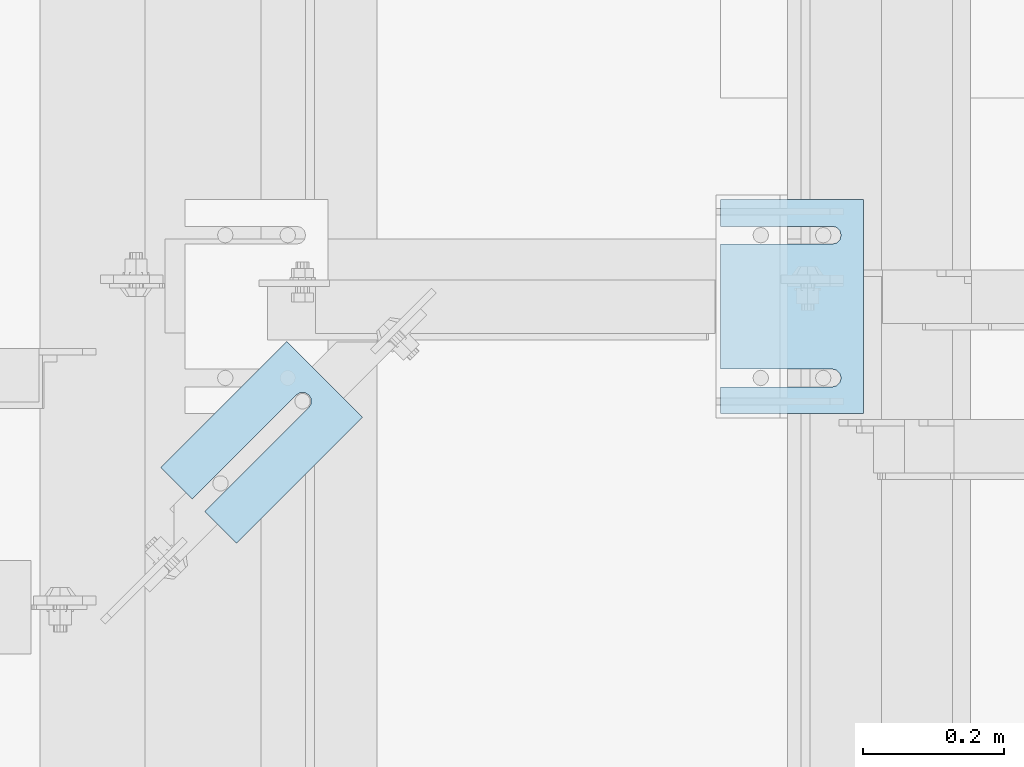
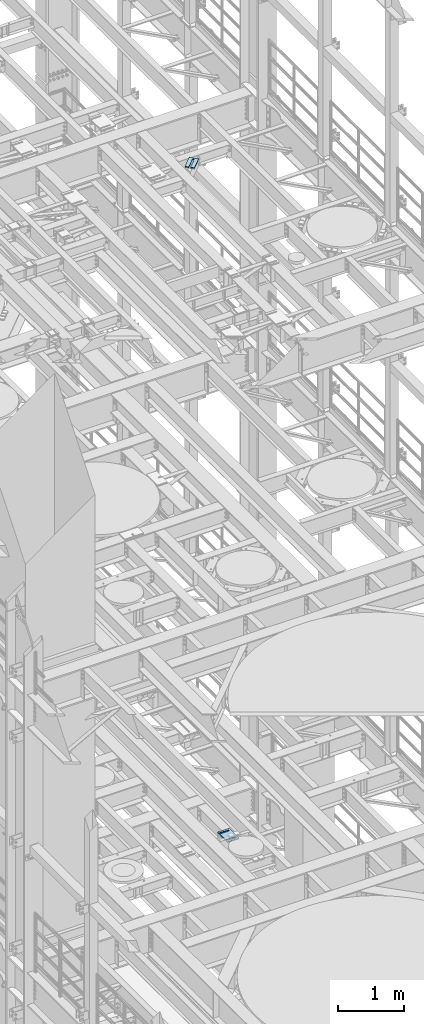
# One storey, part 1726 of 1876: 10 plates, 10 elements without a shape of their own.
"""IFC2X3 building model written with IfcOpenShell, lengths in millimetres."""

from ifc_helpers import new_model, si_unit, frame, origin_with_axes, place, context, subcontext, project, spatial, faceted_brep, material, type_object, element, aggregate, save


model = new_model("IFC2X3")

# Units and contexts
model_context = context("Model", 3, precision=1e-05, world=origin_with_axes())
body_context = subcontext(model_context, "Body", "Model", "MODEL_VIEW")
ifc_project = project(units=[si_unit("LENGTHUNIT", "METRE", prefix="MILLI"), si_unit("AREAUNIT", "SQUARE_METRE"), si_unit("VOLUMEUNIT", "CUBIC_METRE"), si_unit("MASSUNIT", "GRAM", prefix="KILO"), si_unit("TIMEUNIT", "SECOND"), si_unit("PLANEANGLEUNIT", "RADIAN"), si_unit("SOLIDANGLEUNIT", "STERADIAN"), si_unit("THERMODYNAMICTEMPERATUREUNIT", "DEGREE_CELSIUS"), si_unit("LUMINOUSINTENSITYUNIT", "LUMEN")], contexts=[model_context])

# Site, building, storey
site_placement = place(None, origin_with_axes())
site = spatial("IfcSite", under=ifc_project, at=site_placement, CompositionType="ELEMENT")
building_placement = place(site_placement, origin_with_axes())
building = spatial("IfcBuilding", under=site, at=building_placement, Name="Undefined", CompositionType="ELEMENT")
storey_placement = place(building_placement, origin_with_axes())
storey = spatial("IfcBuildingStorey", under=building, at=storey_placement, Name="Undefined", CompositionType="ELEMENT", Elevation=0.0)

# Assembly, plate
assembly_1_placement = place(storey_placement, origin_with_axes())
assembly_1 = element("IfcElementAssembly", 1, at=assembly_1_placement, inside=storey, Name="SHIM PLATE", AssemblyPlace="NOTDEFINED", PredefinedType="RIGID_FRAME")
ifc_material = material(Name="STEEL/A36")
plate_type_1 = type_object("IfcPlateType", PredefinedType="NOTDEFINED")
plate_1_placement = place(assembly_1_placement, frame((5770.74547781455, 6511.95591866753, 18009.3925), z_axis=(0.707131811743501, -0.707081749743517, 0.0), x_axis=(-0.707081749743517, -0.707131811743501, 0.0)))
plate_1 = element("IfcPlate", 2, at=plate_1_placement, type_object=plate_type_1, material=ifc_material, Name="SHIM PLATE", context=body_context, shape_type="Brep", body=[
    faceted_brep([(253.999114990158, -0.793499999999767, 63.5055228916322), (253.999114990158, 0.793499999999767, 63.5055228916322), (44.4486554352061, 0.793499999999767, 63.5055231271672), (44.4486554352061, -0.793499999999767, 63.5055231271672), (38.0987169747023, 0.793499999999767, 65.2072262109032), (38.0987169747023, -0.793499999999767, 65.2072262109032), (33.4503601482247, 0.793499999999767, 69.855913192313), (33.4503601482247, -0.793499999999767, 69.855913192313), (31.7491080645013, 0.793499999999767, 76.2059724979426), (31.7491080645013, -0.793499999999767, 76.2059724979426), (33.4508097177404, 0.793499999999767, 82.555911341803), (33.4508097177404, -0.793499999999767, 82.555911341803), (38.0994956519808, 0.793499999999767, 87.2042692155255), (38.0994956519808, -0.793499999999767, 87.2042692155255), (44.4495545743557, 0.793499999999767, 88.9055227297713), (44.4495545743557, -0.793499999999767, 88.9055227297713), (253.999114989841, -0.793499999999767, 88.8981048472274), (253.999114990158, 0.793499999999767, 88.8981048472274), (253.999114990153, -0.793499999999767, 5.00222085975111e-12), (9.09494701772928e-13, -0.793499999999767, 0.0), (9.09494701772928e-13, 0.793499999999767, 0.0), (253.999114990153, 0.793499999999767, 5.00222085975111e-12), (0.00539501896855654, -0.793499999999767, 152.405197143507), (0.00539501896855654, 0.793499999999767, 152.405197143507), (253.999114990162, -0.793499999999767, 152.405197143493), (253.999114990162, 0.793499999999767, 152.405197143493)], [[[0, 1, 2, 3]], [[3, 2, 4, 5]], [[5, 4, 6, 7]], [[7, 6, 8, 9]], [[9, 8, 10, 11]], [[11, 10, 12, 13]], [[13, 12, 14, 15]], [[16, 15, 14, 17]], [[18, 19, 20, 21]], [[19, 22, 23, 20]], [[22, 24, 25, 23]], [[25, 24, 16, 17]], [[12, 10, 8, 6, 4, 2, 1, 21, 20, 23, 25, 17, 14]], [[18, 21, 1, 0]], [[24, 22, 19, 18, 0, 3, 5, 7, 9, 11, 13, 15, 16]]]),
])
aggregate(assembly_1, [plate_1])

assembly_2_placement = place(storey_placement, origin_with_axes())
assembly_2 = element("IfcElementAssembly", 3, at=assembly_2_placement, inside=storey, Name="SHIM PLATE", AssemblyPlace="NOTDEFINED", PredefinedType="RIGID_FRAME")
plate_type_2 = type_object("IfcPlateType", PredefinedType="NOTDEFINED")
plate_2_placement = place(assembly_2_placement, frame((5770.74547781466, 6511.95591866765, 18007.0115), z_axis=(0.707131811743501, -0.707081749743517, 0.0), x_axis=(-0.707081749743517, -0.707131811743501, 0.0)))
plate_2 = element("IfcPlate", 4, at=plate_2_placement, type_object=plate_type_2, material=ifc_material, Name="SHIM PLATE", context=body_context, shape_type="Brep", body=[
    faceted_brep([(253.999114990158, -1.58750000000146, 63.5055228916326), (253.999114990158, 1.58750000000146, 63.5055228916326), (44.4486554352079, 1.58750000000146, 63.5055231271672), (44.4486554352079, -1.58750000000146, 63.5055231271672), (38.0987169747023, 1.58750000000146, 65.2072262109032), (38.0987169747023, -1.58750000000146, 65.2072262109032), (33.4503601482247, 1.58750000000146, 69.8559131923125), (33.4503601482247, -1.58750000000146, 69.8559131923125), (31.7491080645013, 1.58750000000146, 76.2059724979431), (31.7491080645013, -1.58750000000146, 76.2059724979431), (33.4508097177422, 1.58750000000146, 82.5559113418026), (33.4508097177422, -1.58750000000146, 82.5559113418026), (38.0994956519808, 1.58750000000146, 87.2042692155242), (38.0994956519808, -1.58750000000146, 87.2042692155242), (44.4495545743575, 1.58750000000146, 88.9055227297717), (44.4495545743575, -1.58750000000146, 88.9055227297717), (253.999114989843, -1.58750000000146, 88.8981048472278), (253.99911499016, 1.58750000000146, 88.8981048472278), (253.999114990154, -1.58750000000146, 5.45696821063757e-12), (9.09494701772928e-13, -1.58750000000146, 4.54747350886464e-13), (9.09494701772928e-13, 1.58750000000146, 4.54747350886464e-13), (253.999114990154, 1.58750000000146, 5.45696821063757e-12), (0.00539501896855654, -1.58750000000146, 152.405197143507), (0.00539501896855654, 1.58750000000146, 152.405197143507), (253.999114990163, -1.58750000000146, 152.405197143493), (253.999114990163, 1.58750000000146, 152.405197143493)], [[[0, 1, 2, 3]], [[3, 2, 4, 5]], [[5, 4, 6, 7]], [[7, 6, 8, 9]], [[9, 8, 10, 11]], [[11, 10, 12, 13]], [[13, 12, 14, 15]], [[16, 15, 14, 17]], [[18, 19, 20, 21]], [[19, 22, 23, 20]], [[22, 24, 25, 23]], [[25, 24, 16, 17]], [[12, 10, 8, 6, 4, 2, 1, 21, 20, 23, 25, 17, 14]], [[18, 21, 1, 0]], [[24, 22, 19, 18, 0, 3, 5, 7, 9, 11, 13, 15, 16]]]),
])
aggregate(assembly_2, [plate_2])

assembly_3_placement = place(storey_placement, origin_with_axes())
assembly_3 = element("IfcElementAssembly", 5, at=assembly_3_placement, inside=storey, Name="SHIM PLATE", AssemblyPlace="NOTDEFINED", PredefinedType="RIGID_FRAME")
plate_3_placement = place(assembly_3_placement, frame((5770.74547781477, 6511.95591866776, 18003.8365), z_axis=(0.707131811743501, -0.707081749743517, 0.0), x_axis=(-0.707081749743517, -0.707131811743501, 0.0)))
plate_3 = element("IfcPlate", 6, at=plate_3_placement, type_object=plate_type_2, material=ifc_material, Name="SHIM PLATE", context=body_context, shape_type="Brep", body=[
    faceted_brep([(253.999114990158, -1.58750000000146, 63.5055228916326), (253.999114990158, 1.58750000000146, 63.5055228916326), (44.4486554352079, 1.58750000000146, 63.5055231271672), (44.4486554352079, -1.58750000000146, 63.5055231271672), (38.0987169747023, 1.58750000000146, 65.2072262109032), (38.0987169747023, -1.58750000000146, 65.2072262109032), (33.4503601482247, 1.58750000000146, 69.8559131923125), (33.4503601482247, -1.58750000000146, 69.8559131923125), (31.7491080645013, 1.58750000000146, 76.2059724979431), (31.7491080645013, -1.58750000000146, 76.2059724979431), (33.4508097177422, 1.58750000000146, 82.5559113418026), (33.4508097177422, -1.58750000000146, 82.5559113418026), (38.0994956519808, 1.58750000000146, 87.2042692155242), (38.0994956519808, -1.58750000000146, 87.2042692155242), (44.4495545743575, 1.58750000000146, 88.9055227297717), (44.4495545743575, -1.58750000000146, 88.9055227297717), (253.999114989843, -1.58750000000146, 88.8981048472278), (253.99911499016, 1.58750000000146, 88.8981048472278), (253.999114990154, -1.58750000000146, 5.45696821063757e-12), (9.09494701772928e-13, -1.58750000000146, 4.54747350886464e-13), (9.09494701772928e-13, 1.58750000000146, 4.54747350886464e-13), (253.999114990154, 1.58750000000146, 5.45696821063757e-12), (0.00539501896855654, -1.58750000000146, 152.405197143507), (0.00539501896855654, 1.58750000000146, 152.405197143507), (253.999114990163, -1.58750000000146, 152.405197143493), (253.999114990163, 1.58750000000146, 152.405197143493)], [[[0, 1, 2, 3]], [[3, 2, 4, 5]], [[5, 4, 6, 7]], [[7, 6, 8, 9]], [[9, 8, 10, 11]], [[11, 10, 12, 13]], [[13, 12, 14, 15]], [[16, 15, 14, 17]], [[18, 19, 20, 21]], [[19, 22, 23, 20]], [[22, 24, 25, 23]], [[25, 24, 16, 17]], [[12, 10, 8, 6, 4, 2, 1, 21, 20, 23, 25, 17, 14]], [[18, 21, 1, 0]], [[24, 22, 19, 18, 0, 3, 5, 7, 9, 11, 13, 15, 16]]]),
])
aggregate(assembly_3, [plate_3])

assembly_4_placement = place(storey_placement, origin_with_axes())
assembly_4 = element("IfcElementAssembly", 7, at=assembly_4_placement, inside=storey, Name="SHIM PLATE", AssemblyPlace="NOTDEFINED", PredefinedType="RIGID_FRAME")
plate_type_3 = type_object("IfcPlateType", PredefinedType="NOTDEFINED")
plate_4_placement = place(assembly_4_placement, frame((5770.74547781488, 6511.95591866787, 17999.868), z_axis=(0.707131811743501, -0.707081749743517, 0.0), x_axis=(-0.707081749743517, -0.707131811743501, 0.0)))
plate_4 = element("IfcPlate", 8, at=plate_4_placement, type_object=plate_type_3, material=ifc_material, Name="SHIM PLATE", context=body_context, shape_type="Brep", body=[
    faceted_brep([(253.999114990158, -2.38100000000122, 63.5055228916324), (253.999114990158, 2.38100000000122, 63.5055228916324), (44.4486554352079, 2.38100000000122, 63.5055231271674), (44.4486554352079, -2.38100000000122, 63.5055231271674), (38.0987169747041, 2.38100000000122, 65.2072262109034), (38.0987169747041, -2.38100000000122, 65.2072262109034), (33.4503601482247, 2.38100000000122, 69.8559131923118), (33.4503601482247, -2.38100000000122, 69.8559131923118), (31.7491080645032, 2.38100000000122, 76.2059724979433), (31.7491080645032, -2.38100000000122, 76.2059724979433), (33.4508097177404, 2.38100000000122, 82.5559113418028), (33.4508097177404, -2.38100000000122, 82.5559113418028), (38.0994956519808, 2.38100000000122, 87.2042692155244), (38.0994956519808, -2.38100000000122, 87.2042692155244), (44.4495545743575, 2.38100000000122, 88.905522729772), (44.4495545743575, -2.38100000000122, 88.905522729772), (253.999114989843, -2.38100000000122, 88.8981048472276), (253.99911499016, 2.38100000000122, 88.8981048472276), (253.999114990154, -2.38100000000122, 3.41060513164848e-12), (0.0, -2.38100000000122, 4.54747350886464e-13), (0.0, 2.38100000000122, 4.54747350886464e-13), (253.999114990154, 2.38100000000122, 3.41060513164848e-12), (0.00539501897037553, -2.38100000000122, 152.405197143507), (0.00539501897037553, 2.38100000000122, 152.405197143507), (253.999114990163, -2.38100000000122, 152.405197143492), (253.999114990163, 2.38100000000122, 152.405197143492)], [[[0, 1, 2, 3]], [[3, 2, 4, 5]], [[5, 4, 6, 7]], [[7, 6, 8, 9]], [[9, 8, 10, 11]], [[11, 10, 12, 13]], [[13, 12, 14, 15]], [[16, 15, 14, 17]], [[18, 19, 20, 21]], [[19, 22, 23, 20]], [[22, 24, 25, 23]], [[25, 24, 16, 17]], [[12, 10, 8, 6, 4, 2, 1, 21, 20, 23, 25, 17, 14]], [[18, 21, 1, 0]], [[24, 22, 19, 18, 0, 3, 5, 7, 9, 11, 13, 15, 16]]]),
])
aggregate(assembly_4, [plate_4])

assembly_5_placement = place(storey_placement, origin_with_axes())
assembly_5 = element("IfcElementAssembly", 9, at=assembly_5_placement, inside=storey, Name="SHIM PLATE", AssemblyPlace="NOTDEFINED", PredefinedType="RIGID_FRAME")
plate_5_placement = place(assembly_5_placement, frame((5770.74547781499, 6511.95591866798, 17995.106), z_axis=(0.707131811743501, -0.707081749743517, 0.0), x_axis=(-0.707081749743517, -0.707131811743501, 0.0)))
plate_5 = element("IfcPlate", 10, at=plate_5_placement, type_object=plate_type_3, material=ifc_material, Name="SHIM PLATE", context=body_context, shape_type="Brep", body=[
    faceted_brep([(253.999114990158, -2.38100000000122, 63.5055228916324), (253.999114990158, 2.38100000000122, 63.5055228916324), (44.4486554352079, 2.38100000000122, 63.5055231271674), (44.4486554352079, -2.38100000000122, 63.5055231271674), (38.0987169747041, 2.38100000000122, 65.2072262109034), (38.0987169747041, -2.38100000000122, 65.2072262109034), (33.4503601482247, 2.38100000000122, 69.8559131923118), (33.4503601482247, -2.38100000000122, 69.8559131923118), (31.7491080645032, 2.38100000000122, 76.2059724979433), (31.7491080645032, -2.38100000000122, 76.2059724979433), (33.4508097177404, 2.38100000000122, 82.5559113418028), (33.4508097177404, -2.38100000000122, 82.5559113418028), (38.0994956519808, 2.38100000000122, 87.2042692155244), (38.0994956519808, -2.38100000000122, 87.2042692155244), (44.4495545743575, 2.38100000000122, 88.905522729772), (44.4495545743575, -2.38100000000122, 88.905522729772), (253.999114989843, -2.38100000000122, 88.8981048472276), (253.99911499016, 2.38100000000122, 88.8981048472276), (253.999114990154, -2.38100000000122, 3.41060513164848e-12), (0.0, -2.38100000000122, 4.54747350886464e-13), (0.0, 2.38100000000122, 4.54747350886464e-13), (253.999114990154, 2.38100000000122, 3.41060513164848e-12), (0.00539501897037553, -2.38100000000122, 152.405197143507), (0.00539501897037553, 2.38100000000122, 152.405197143507), (253.999114990163, -2.38100000000122, 152.405197143492), (253.999114990163, 2.38100000000122, 152.405197143492)], [[[0, 1, 2, 3]], [[3, 2, 4, 5]], [[5, 4, 6, 7]], [[7, 6, 8, 9]], [[9, 8, 10, 11]], [[11, 10, 12, 13]], [[13, 12, 14, 15]], [[16, 15, 14, 17]], [[18, 19, 20, 21]], [[19, 22, 23, 20]], [[22, 24, 25, 23]], [[25, 24, 16, 17]], [[12, 10, 8, 6, 4, 2, 1, 21, 20, 23, 25, 17, 14]], [[18, 21, 1, 0]], [[24, 22, 19, 18, 0, 3, 5, 7, 9, 11, 13, 15, 16]]]),
])
aggregate(assembly_5, [plate_5])

assembly_6_placement = place(storey_placement, origin_with_axes())
assembly_6 = element("IfcElementAssembly", 11, at=assembly_6_placement, inside=storey, Name="SHIM PLATE", AssemblyPlace="NOTDEFINED", PredefinedType="RIGID_FRAME")
plate_type_4 = type_object("IfcPlateType", PredefinedType="NOTDEFINED")
plate_6_placement = place(assembly_6_placement, frame((6591.29886163347, 6713.78228759766, 5156.9925), z_axis=(0.0, -1.0, 0.0), x_axis=(-1.0, 0.0, 0.0)))
plate_6 = element("IfcPlate", 12, at=plate_6_placement, type_object=plate_type_4, material=ifc_material, Name="SHIM PLATE", context=body_context, shape_type="Brep", body=[
    faceted_brep([(203.203060149864, -0.793499999999767, 38.103375484061), (203.203060149864, 0.793499999999767, 38.103375484061), (44.4515180349072, 0.793499999999767, 38.1033599194234), (44.4515180349072, -0.793499999999767, 38.1033599194234), (38.1012989900946, 0.793499999999767, 39.8049650059329), (38.1012989900946, -0.793499999999767, 39.8049650059329), (33.4527432566938, 0.793499999999767, 44.4538004924834), (33.4527432566938, -0.793499999999767, 44.4538004924834), (31.7515203221337, 0.793499999999767, 50.8041219264314), (31.7515203221337, -0.793499999999767, 50.8041219264314), (33.4535054350818, 0.793499999999767, 57.1542391271487), (33.4535054350818, -0.793499999999767, 57.1542391271487), (38.1026191065821, 0.793499999999767, 61.8025166422076), (38.1026191065821, -0.793499999999767, 61.8025166422076), (44.4530423390133, 0.793499999999767, 63.5033595381083), (44.4530423390133, -0.793499999999767, 63.5033595381083), (203.203057597802, -0.793499999999767, 63.5033693805453), (203.203057606771, 0.793499999999767, 63.5033693805453), (203.203063964842, -0.793499999999767, -8.45830072648823e-11), (9.09494701772928e-13, -0.793499999999767, 0.0), (9.09494701772928e-13, 0.793499999999767, 0.0), (203.203063964842, 0.793499999999767, -8.45830072648823e-11), (-1.83106603799388e-05, -0.793499999999767, 304.8037109375), (-1.83106603799388e-05, 0.793499999999767, 304.8037109375), (203.203033447349, -0.793499999999767, 304.803710937444), (203.203033447349, 0.793499999999767, 304.803710937444), (203.20303725321, -0.793499999999767, 266.701819087575), (203.203037262178, 0.793499999999767, 266.701819087575), (44.4530372532099, -0.793499999999767, 266.701809245139), (44.4530372532099, 0.793499999999767, 266.701809245139), (38.1026140207787, -0.793499999999767, 265.000966349239), (38.1026140207787, 0.793499999999767, 265.000966349239), (33.4535003492774, -0.793499999999767, 260.352688834179), (33.4535003492774, 0.793499999999767, 260.352688834179), (31.7515152363312, -0.793499999999767, 254.002571633462), (31.7515152363312, 0.793499999999767, 254.002571633462), (33.4527381708904, -0.793499999999767, 247.652250199514), (33.4527381708904, 0.793499999999767, 247.652250199514), (38.1012939042912, -0.793499999999767, 243.003414712964), (38.1012939042912, 0.793499999999767, 243.003414712964), (44.4515129491037, -0.793499999999767, 241.301809626454), (44.4515129491037, 0.793499999999767, 241.301809626454), (203.203039805271, -0.793499999999767, 241.301825191091), (203.203039805271, 0.793499999999767, 241.301825191091)], [[[0, 1, 2, 3]], [[3, 2, 4, 5]], [[5, 4, 6, 7]], [[7, 6, 8, 9]], [[9, 8, 10, 11]], [[11, 10, 12, 13]], [[13, 12, 14, 15]], [[16, 15, 14, 17]], [[18, 19, 20, 21]], [[19, 22, 23, 20]], [[22, 24, 25, 23]], [[25, 24, 26, 27]], [[26, 28, 29, 27]], [[30, 31, 29, 28]], [[32, 33, 31, 30]], [[34, 35, 33, 32]], [[36, 37, 35, 34]], [[38, 39, 37, 36]], [[40, 41, 39, 38]], [[42, 43, 41, 40]], [[43, 42, 16, 17]], [[12, 10, 8, 6, 4, 2, 1, 21, 20, 23, 25, 27, 29, 31, 33, 35, 37, 39, 41, 43, 17, 14]], [[18, 21, 1, 0]], [[42, 40, 38, 36, 34, 32, 30, 28, 26, 24, 22, 19, 18, 0, 3, 5, 7, 9, 11, 13, 15, 16]]]),
])
aggregate(assembly_6, [plate_6])

assembly_7_placement = place(storey_placement, origin_with_axes())
assembly_7 = element("IfcElementAssembly", 13, at=assembly_7_placement, inside=storey, Name="SHIM PLATE", AssemblyPlace="NOTDEFINED", PredefinedType="RIGID_FRAME")
plate_type_5 = type_object("IfcPlateType", PredefinedType="NOTDEFINED")
plate_7_placement = place(assembly_7_placement, frame((6591.29886163347, 6713.78228759766, 5154.6115), z_axis=(0.0, -1.0, 0.0), x_axis=(-1.0, 0.0, 0.0)))
plate_7 = element("IfcPlate", 14, at=plate_7_placement, type_object=plate_type_5, material=ifc_material, Name="SHIM PLATE", context=body_context, shape_type="Brep", body=[
    faceted_brep([(203.203060149865, -1.58749999999964, 38.1033754840619), (203.203060149865, 1.58749999999964, 38.1033754840619), (44.4515180349081, 1.58749999999964, 38.1033599194243), (44.4515180349081, -1.58749999999964, 38.1033599194243), (38.1012989900955, 1.58749999999964, 39.8049650059338), (38.1012989900955, -1.58749999999964, 39.8049650059338), (33.4527432566947, 1.58749999999964, 44.4538004924843), (33.4527432566947, -1.58749999999964, 44.4538004924843), (31.7515203221346, 1.58749999999964, 50.8041219264323), (31.7515203221346, -1.58749999999964, 50.8041219264323), (33.4535054350827, 1.58749999999964, 57.1542391271496), (33.4535054350827, -1.58749999999964, 57.1542391271496), (38.102619106583, 1.58749999999964, 61.8025166422085), (38.102619106583, -1.58749999999964, 61.8025166422085), (44.4530423390142, 1.58749999999964, 63.5033595381092), (44.4530423390142, -1.58749999999964, 63.5033595381092), (203.203057597803, -1.58749999999964, 63.5033693805462), (203.203057606772, 1.58749999999964, 63.5033693805462), (203.203063964843, -1.58749999999964, -8.36735125631094e-11), (9.09494701772928e-13, -1.58750000000146, 4.54747350886464e-13), (9.09494701772928e-13, 1.58750000000146, 4.54747350886464e-13), (203.203063964843, 1.58749999999964, -8.36735125631094e-11), (-1.83106631084229e-05, -1.58749999999964, 304.803710937501), (-1.83106631084229e-05, 1.58749999999964, 304.803710937501), (203.20303344735, -1.58749999999964, 304.803710937445), (203.20303344735, 1.58749999999964, 304.803710937445), (203.203037253211, -1.58749999999964, 266.701819087576), (203.203037262179, 1.58749999999964, 266.701819087576), (44.4530372532108, -1.58749999999964, 266.70180924514), (44.4530372532108, 1.58749999999964, 266.70180924514), (38.1026140207796, -1.58749999999964, 265.00096634924), (38.1026140207796, 1.58749999999964, 265.00096634924), (33.4535003492783, -1.58749999999964, 260.35268883418), (33.4535003492783, 1.58749999999964, 260.35268883418), (31.7515152363321, -1.58749999999964, 254.002571633463), (31.7515152363321, 1.58749999999964, 254.002571633463), (33.4527381708913, -1.58749999999964, 247.652250199515), (33.4527381708913, 1.58749999999964, 247.652250199515), (38.1012939042921, -1.58749999999964, 243.003414712965), (38.1012939042921, 1.58749999999964, 243.003414712965), (44.4515129491047, -1.58749999999964, 241.301809626455), (44.4515129491047, 1.58749999999964, 241.301809626455), (203.203039805272, -1.58749999999964, 241.301825191092), (203.203039805272, 1.58749999999964, 241.301825191092)], [[[0, 1, 2, 3]], [[3, 2, 4, 5]], [[5, 4, 6, 7]], [[7, 6, 8, 9]], [[9, 8, 10, 11]], [[11, 10, 12, 13]], [[13, 12, 14, 15]], [[16, 15, 14, 17]], [[18, 19, 20, 21]], [[19, 22, 23, 20]], [[22, 24, 25, 23]], [[25, 24, 26, 27]], [[26, 28, 29, 27]], [[30, 31, 29, 28]], [[32, 33, 31, 30]], [[34, 35, 33, 32]], [[36, 37, 35, 34]], [[38, 39, 37, 36]], [[40, 41, 39, 38]], [[42, 43, 41, 40]], [[43, 42, 16, 17]], [[12, 10, 8, 6, 4, 2, 1, 21, 20, 23, 25, 27, 29, 31, 33, 35, 37, 39, 41, 43, 17, 14]], [[18, 21, 1, 0]], [[42, 40, 38, 36, 34, 32, 30, 28, 26, 24, 22, 19, 18, 0, 3, 5, 7, 9, 11, 13, 15, 16]]]),
])
aggregate(assembly_7, [plate_7])

assembly_8_placement = place(storey_placement, origin_with_axes())
assembly_8 = element("IfcElementAssembly", 15, at=assembly_8_placement, inside=storey, Name="SHIM PLATE", AssemblyPlace="NOTDEFINED", PredefinedType="RIGID_FRAME")
plate_8_placement = place(assembly_8_placement, frame((6591.29886163347, 6713.78228759766, 5151.4365), z_axis=(0.0, -1.0, 0.0), x_axis=(-1.0, 0.0, 0.0)))
plate_8 = element("IfcPlate", 16, at=plate_8_placement, type_object=plate_type_5, material=ifc_material, Name="SHIM PLATE", context=body_context, shape_type="Brep", body=[
    faceted_brep([(203.203060149865, -1.58749999999964, 38.1033754840619), (203.203060149865, 1.58749999999964, 38.1033754840619), (44.4515180349081, 1.58749999999964, 38.1033599194243), (44.4515180349081, -1.58749999999964, 38.1033599194243), (38.1012989900955, 1.58749999999964, 39.8049650059338), (38.1012989900955, -1.58749999999964, 39.8049650059338), (33.4527432566947, 1.58749999999964, 44.4538004924843), (33.4527432566947, -1.58749999999964, 44.4538004924843), (31.7515203221346, 1.58749999999964, 50.8041219264323), (31.7515203221346, -1.58749999999964, 50.8041219264323), (33.4535054350827, 1.58749999999964, 57.1542391271496), (33.4535054350827, -1.58749999999964, 57.1542391271496), (38.102619106583, 1.58749999999964, 61.8025166422085), (38.102619106583, -1.58749999999964, 61.8025166422085), (44.4530423390142, 1.58749999999964, 63.5033595381092), (44.4530423390142, -1.58749999999964, 63.5033595381092), (203.203057597803, -1.58749999999964, 63.5033693805462), (203.203057606772, 1.58749999999964, 63.5033693805462), (203.203063964843, -1.58749999999964, -8.36735125631094e-11), (9.09494701772928e-13, -1.58750000000146, 4.54747350886464e-13), (9.09494701772928e-13, 1.58750000000146, 4.54747350886464e-13), (203.203063964843, 1.58749999999964, -8.36735125631094e-11), (-1.83106631084229e-05, -1.58749999999964, 304.803710937501), (-1.83106631084229e-05, 1.58749999999964, 304.803710937501), (203.20303344735, -1.58749999999964, 304.803710937445), (203.20303344735, 1.58749999999964, 304.803710937445), (203.203037253211, -1.58749999999964, 266.701819087576), (203.203037262179, 1.58749999999964, 266.701819087576), (44.4530372532108, -1.58749999999964, 266.70180924514), (44.4530372532108, 1.58749999999964, 266.70180924514), (38.1026140207796, -1.58749999999964, 265.00096634924), (38.1026140207796, 1.58749999999964, 265.00096634924), (33.4535003492783, -1.58749999999964, 260.35268883418), (33.4535003492783, 1.58749999999964, 260.35268883418), (31.7515152363321, -1.58749999999964, 254.002571633463), (31.7515152363321, 1.58749999999964, 254.002571633463), (33.4527381708913, -1.58749999999964, 247.652250199515), (33.4527381708913, 1.58749999999964, 247.652250199515), (38.1012939042921, -1.58749999999964, 243.003414712965), (38.1012939042921, 1.58749999999964, 243.003414712965), (44.4515129491047, -1.58749999999964, 241.301809626455), (44.4515129491047, 1.58749999999964, 241.301809626455), (203.203039805272, -1.58749999999964, 241.301825191092), (203.203039805272, 1.58749999999964, 241.301825191092)], [[[0, 1, 2, 3]], [[3, 2, 4, 5]], [[5, 4, 6, 7]], [[7, 6, 8, 9]], [[9, 8, 10, 11]], [[11, 10, 12, 13]], [[13, 12, 14, 15]], [[16, 15, 14, 17]], [[18, 19, 20, 21]], [[19, 22, 23, 20]], [[22, 24, 25, 23]], [[25, 24, 26, 27]], [[26, 28, 29, 27]], [[30, 31, 29, 28]], [[32, 33, 31, 30]], [[34, 35, 33, 32]], [[36, 37, 35, 34]], [[38, 39, 37, 36]], [[40, 41, 39, 38]], [[42, 43, 41, 40]], [[43, 42, 16, 17]], [[12, 10, 8, 6, 4, 2, 1, 21, 20, 23, 25, 27, 29, 31, 33, 35, 37, 39, 41, 43, 17, 14]], [[18, 21, 1, 0]], [[42, 40, 38, 36, 34, 32, 30, 28, 26, 24, 22, 19, 18, 0, 3, 5, 7, 9, 11, 13, 15, 16]]]),
])
aggregate(assembly_8, [plate_8])

assembly_9_placement = place(storey_placement, origin_with_axes())
assembly_9 = element("IfcElementAssembly", 17, at=assembly_9_placement, inside=storey, Name="SHIM PLATE", AssemblyPlace="NOTDEFINED", PredefinedType="RIGID_FRAME")
plate_type_6 = type_object("IfcPlateType", PredefinedType="NOTDEFINED")
plate_9_placement = place(assembly_9_placement, frame((6591.29886163347, 6713.78228759766, 5147.468), z_axis=(0.0, -1.0, 0.0), x_axis=(-1.0, 0.0, 0.0)))
plate_9 = element("IfcPlate", 18, at=plate_9_placement, type_object=plate_type_6, material=ifc_material, Name="SHIM PLATE", context=body_context, shape_type="Brep", body=[
    faceted_brep([(203.203060149865, -2.38100000000031, 38.1033754840619), (203.203060149865, 2.38100000000031, 38.1033754840619), (44.4515180349081, 2.38100000000031, 38.1033599194243), (44.4515180349081, -2.38100000000031, 38.1033599194243), (38.1012989900955, 2.38100000000031, 39.8049650059338), (38.1012989900955, -2.38100000000031, 39.8049650059338), (33.4527432566947, 2.38100000000031, 44.4538004924843), (33.4527432566947, -2.38100000000031, 44.4538004924843), (31.7515203221346, 2.38100000000031, 50.8041219264323), (31.7515203221346, -2.38100000000031, 50.8041219264323), (33.4535054350827, 2.38100000000031, 57.1542391271496), (33.4535054350827, -2.38100000000031, 57.1542391271496), (38.102619106583, 2.38100000000031, 61.8025166422085), (38.102619106583, -2.38100000000031, 61.8025166422085), (44.4530423390142, 2.38100000000031, 63.5033595381092), (44.4530423390142, -2.38100000000031, 63.5033595381092), (203.203057597803, -2.38100000000031, 63.5033693805462), (203.203057606772, 2.38100000000031, 63.5033693805462), (203.203063964843, -2.38100000000031, -8.36735125631094e-11), (0.0, -2.38100000000122, 4.54747350886464e-13), (0.0, 2.38100000000122, 4.54747350886464e-13), (203.203063964843, 2.38100000000031, -8.36735125631094e-11), (-1.83106667464017e-05, -2.38100000000031, 304.803710937501), (-1.83106667464017e-05, 2.38100000000031, 304.803710937501), (203.20303344735, -2.38100000000031, 304.803710937445), (203.20303344735, 2.38100000000031, 304.803710937445), (203.203037253211, -2.38100000000031, 266.701819087576), (203.203037262179, 2.38100000000031, 266.701819087576), (44.4530372532108, -2.38100000000031, 266.70180924514), (44.4530372532108, 2.38100000000031, 266.70180924514), (38.1026140207796, -2.38100000000031, 265.00096634924), (38.1026140207796, 2.38100000000031, 265.00096634924), (33.4535003492783, -2.38100000000031, 260.35268883418), (33.4535003492783, 2.38100000000031, 260.35268883418), (31.7515152363321, -2.38100000000031, 254.002571633463), (31.7515152363321, 2.38100000000031, 254.002571633463), (33.4527381708913, -2.38100000000031, 247.652250199515), (33.4527381708913, 2.38100000000031, 247.652250199515), (38.1012939042921, -2.38100000000031, 243.003414712965), (38.1012939042921, 2.38100000000031, 243.003414712965), (44.4515129491047, -2.38100000000031, 241.301809626455), (44.4515129491047, 2.38100000000031, 241.301809626455), (203.203039805272, -2.38100000000031, 241.301825191092), (203.203039805272, 2.38100000000031, 241.301825191092)], [[[0, 1, 2, 3]], [[3, 2, 4, 5]], [[5, 4, 6, 7]], [[7, 6, 8, 9]], [[9, 8, 10, 11]], [[11, 10, 12, 13]], [[13, 12, 14, 15]], [[16, 15, 14, 17]], [[18, 19, 20, 21]], [[19, 22, 23, 20]], [[22, 24, 25, 23]], [[25, 24, 26, 27]], [[26, 28, 29, 27]], [[30, 31, 29, 28]], [[32, 33, 31, 30]], [[34, 35, 33, 32]], [[36, 37, 35, 34]], [[38, 39, 37, 36]], [[40, 41, 39, 38]], [[42, 43, 41, 40]], [[43, 42, 16, 17]], [[12, 10, 8, 6, 4, 2, 1, 21, 20, 23, 25, 27, 29, 31, 33, 35, 37, 39, 41, 43, 17, 14]], [[18, 21, 1, 0]], [[42, 40, 38, 36, 34, 32, 30, 28, 26, 24, 22, 19, 18, 0, 3, 5, 7, 9, 11, 13, 15, 16]]]),
])
aggregate(assembly_9, [plate_9])

assembly_10_placement = place(storey_placement, origin_with_axes())
assembly_10 = element("IfcElementAssembly", 19, at=assembly_10_placement, inside=storey, Name="SHIM PLATE", AssemblyPlace="NOTDEFINED", PredefinedType="RIGID_FRAME")
plate_10_placement = place(assembly_10_placement, frame((6591.29886163347, 6713.78228759766, 5142.706), z_axis=(0.0, -1.0, 0.0), x_axis=(-1.0, 0.0, 0.0)))
plate_10 = element("IfcPlate", 20, at=plate_10_placement, type_object=plate_type_6, material=ifc_material, Name="SHIM PLATE", context=body_context, shape_type="Brep", body=[
    faceted_brep([(203.203060149865, -2.38100000000031, 38.1033754840619), (203.203060149865, 2.38100000000031, 38.1033754840619), (44.4515180349081, 2.38100000000031, 38.1033599194243), (44.4515180349081, -2.38100000000031, 38.1033599194243), (38.1012989900955, 2.38100000000031, 39.8049650059338), (38.1012989900955, -2.38100000000031, 39.8049650059338), (33.4527432566947, 2.38100000000031, 44.4538004924843), (33.4527432566947, -2.38100000000031, 44.4538004924843), (31.7515203221346, 2.38100000000031, 50.8041219264323), (31.7515203221346, -2.38100000000031, 50.8041219264323), (33.4535054350827, 2.38100000000031, 57.1542391271496), (33.4535054350827, -2.38100000000031, 57.1542391271496), (38.102619106583, 2.38100000000031, 61.8025166422085), (38.102619106583, -2.38100000000031, 61.8025166422085), (44.4530423390142, 2.38100000000031, 63.5033595381092), (44.4530423390142, -2.38100000000031, 63.5033595381092), (203.203057597803, -2.38100000000031, 63.5033693805462), (203.203057606772, 2.38100000000031, 63.5033693805462), (203.203063964843, -2.38100000000031, -8.36735125631094e-11), (0.0, -2.38100000000122, 4.54747350886464e-13), (0.0, 2.38100000000122, 4.54747350886464e-13), (203.203063964843, 2.38100000000031, -8.36735125631094e-11), (-1.83106667464017e-05, -2.38100000000031, 304.803710937501), (-1.83106667464017e-05, 2.38100000000031, 304.803710937501), (203.20303344735, -2.38100000000031, 304.803710937445), (203.20303344735, 2.38100000000031, 304.803710937445), (203.203037253211, -2.38100000000031, 266.701819087576), (203.203037262179, 2.38100000000031, 266.701819087576), (44.4530372532108, -2.38100000000031, 266.70180924514), (44.4530372532108, 2.38100000000031, 266.70180924514), (38.1026140207796, -2.38100000000031, 265.00096634924), (38.1026140207796, 2.38100000000031, 265.00096634924), (33.4535003492783, -2.38100000000031, 260.35268883418), (33.4535003492783, 2.38100000000031, 260.35268883418), (31.7515152363321, -2.38100000000031, 254.002571633463), (31.7515152363321, 2.38100000000031, 254.002571633463), (33.4527381708913, -2.38100000000031, 247.652250199515), (33.4527381708913, 2.38100000000031, 247.652250199515), (38.1012939042921, -2.38100000000031, 243.003414712965), (38.1012939042921, 2.38100000000031, 243.003414712965), (44.4515129491047, -2.38100000000031, 241.301809626455), (44.4515129491047, 2.38100000000031, 241.301809626455), (203.203039805272, -2.38100000000031, 241.301825191092), (203.203039805272, 2.38100000000031, 241.301825191092)], [[[0, 1, 2, 3]], [[3, 2, 4, 5]], [[5, 4, 6, 7]], [[7, 6, 8, 9]], [[9, 8, 10, 11]], [[11, 10, 12, 13]], [[13, 12, 14, 15]], [[16, 15, 14, 17]], [[18, 19, 20, 21]], [[19, 22, 23, 20]], [[22, 24, 25, 23]], [[25, 24, 26, 27]], [[26, 28, 29, 27]], [[30, 31, 29, 28]], [[32, 33, 31, 30]], [[34, 35, 33, 32]], [[36, 37, 35, 34]], [[38, 39, 37, 36]], [[40, 41, 39, 38]], [[42, 43, 41, 40]], [[43, 42, 16, 17]], [[12, 10, 8, 6, 4, 2, 1, 21, 20, 23, 25, 27, 29, 31, 33, 35, 37, 39, 41, 43, 17, 14]], [[18, 21, 1, 0]], [[42, 40, 38, 36, 34, 32, 30, 28, 26, 24, 22, 19, 18, 0, 3, 5, 7, 9, 11, 13, 15, 16]]]),
])
aggregate(assembly_10, [plate_10])

save(model, "model.ifc")
